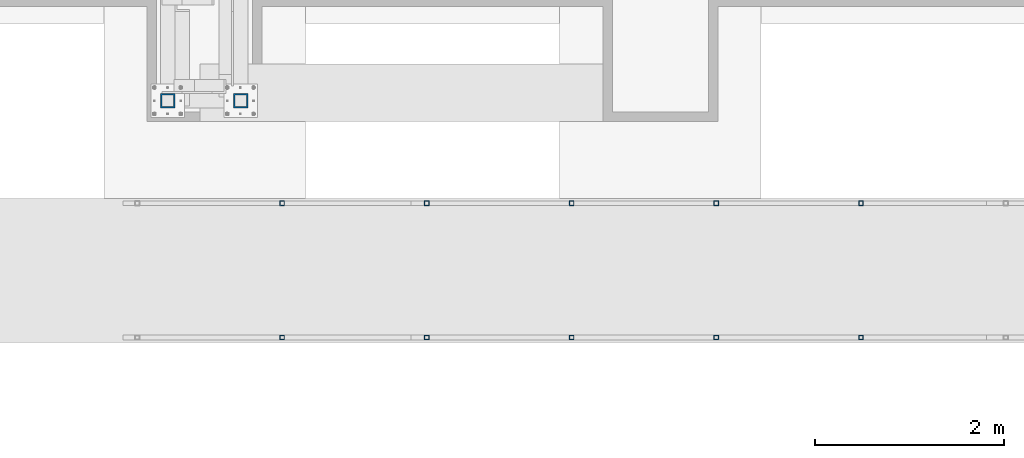
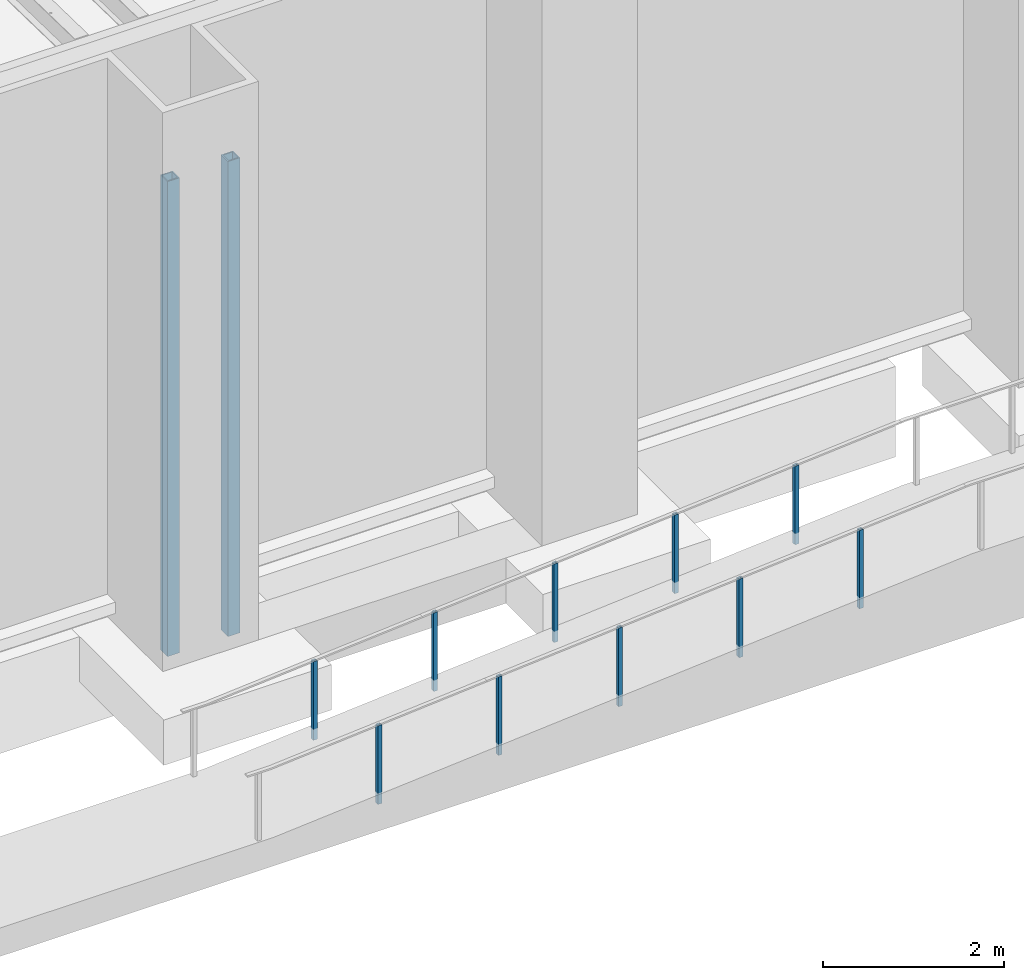
# One storey, part 876 of 1763: 12 columns, 5 elements without a shape of their own.
"""IFC2X3 building model written with IfcOpenShell, lengths in millimetres."""

from ifc_helpers import new_model, si_unit, frame, origin_with_axes, place, context, subcontext, project, spatial, faceted_brep, material, type_object, element, aggregate, save


model = new_model("IFC2X3")

# Units and contexts
model_context = context("Model", 3, precision=1e-05, world=origin_with_axes())
body_context = subcontext(model_context, "Body", "Model", "MODEL_VIEW")
ifc_project = project(units=[si_unit("LENGTHUNIT", "METRE", prefix="MILLI"), si_unit("AREAUNIT", "SQUARE_METRE"), si_unit("VOLUMEUNIT", "CUBIC_METRE"), si_unit("MASSUNIT", "GRAM", prefix="KILO"), si_unit("TIMEUNIT", "SECOND"), si_unit("PLANEANGLEUNIT", "RADIAN"), si_unit("SOLIDANGLEUNIT", "STERADIAN"), si_unit("THERMODYNAMICTEMPERATUREUNIT", "DEGREE_CELSIUS"), si_unit("LUMINOUSINTENSITYUNIT", "LUMEN")], contexts=[model_context])

# Site, building, storey
site_placement = place(None, origin_with_axes())
site = spatial("IfcSite", under=ifc_project, at=site_placement, CompositionType="ELEMENT")
building_placement = place(site_placement, origin_with_axes())
building = spatial("IfcBuilding", under=site, at=building_placement, Name="Undefined", CompositionType="ELEMENT")
storey_placement = place(building_placement, origin_with_axes())
storey = spatial("IfcBuildingStorey", under=building, at=storey_placement, Name="Undefined", CompositionType="ELEMENT", Elevation=0.0)

# Assembly, columns
assembly_1_placement = place(storey_placement, origin_with_axes())
assembly_1 = element("IfcElementAssembly", 1, at=assembly_1_placement, inside=storey, Name="FRAME", AssemblyPlace="NOTDEFINED", PredefinedType="RIGID_FRAME")
ifc_material = material()
column_type_1 = type_object("IfcColumnType", Name="HSS6X6X5/8", PredefinedType="NOTDEFINED")
column_1_placement = place(assembly_1_placement, frame((-80212.6370783858, -15452.7242675181, 5029.2), z_axis=(0.0, 1.0, 0.0), x_axis=(0.0, 0.0, 1.0)))
column_1 = element("IfcColumn", 2, at=column_1_placement, type_object=column_type_1, material=ifc_material, Name="COLUMN", ObjectType="HSS6X6X5/8", context=body_context, shape_type="Brep", body=[
    faceted_brep([(63.4999999999973, 60.3249999999971, -60.3250000000007), (63.4999999999973, -60.3249999999971, -60.3250000000007), (6457.95, -60.3249999999971, -60.3250000000007), (6457.95, 60.3249999999971, -60.3250000000007), (63.4999999999973, -60.3249999999971, 60.3250000000007), (6457.95, -60.3249999999971, 60.3250000000007), (63.4999999999973, 60.3249999999971, 60.3250000000007), (6457.95, 60.3249999999971, 60.3250000000007), (63.4999999999973, 76.1999999999971, -76.2000000000007), (63.4999999999973, 76.1999999999971, 76.2000000000007), (6457.95, 76.1999999999971, 76.2000000000007), (6457.95, 76.1999999999971, -76.2000000000007), (63.4999999999973, -76.1999999999971, 76.2000000000007), (6457.95, -76.1999999999971, 76.2000000000007), (63.4999999999973, -76.1999999999971, -76.2000000000007), (6457.95, -76.1999999999971, -76.2000000000007)], [[[0, 1, 2, 3]], [[1, 4, 5, 2]], [[4, 6, 7, 5]], [[6, 0, 3, 7]], [[8, 9, 10, 11]], [[9, 12, 13, 10]], [[12, 14, 15, 13]], [[14, 8, 11, 15]], [[13, 15, 11, 10], [5, 7, 3, 2]], [[14, 12, 9, 8], [6, 4, 1, 0]]]),
])
column_2_placement = place(assembly_1_placement, frame((-80984.1622736984, -15452.7242675181, 5029.2), z_axis=(0.0, 1.0, 0.0), x_axis=(0.0, 0.0, 1.0)))
column_2 = element("IfcColumn", 3, at=column_2_placement, type_object=column_type_1, material=ifc_material, Name="FRAME", ObjectType="HSS6X6X5/8", context=body_context, shape_type="Brep", body=[
    faceted_brep([(63.4999999999973, 60.3249999999971, -60.3250000000007), (63.4999999999973, -60.3249999999971, -60.3250000000007), (6457.95, -60.3249999999971, -60.3250000000007), (6457.95, 60.3249999999971, -60.3250000000007), (63.4999999999973, -60.3249999999971, 60.3250000000007), (6457.95, -60.3249999999971, 60.3250000000007), (63.4999999999973, 60.3249999999971, 60.3250000000007), (6457.95, 60.3249999999971, 60.3250000000007), (63.4999999999973, 76.1999999999971, -76.2000000000007), (63.4999999999973, 76.1999999999971, 76.2000000000007), (6457.95, 76.1999999999971, 76.2000000000007), (6457.95, 76.1999999999971, -76.2000000000007), (63.4999999999973, -76.1999999999971, 76.2000000000007), (6457.95, -76.1999999999971, 76.2000000000007), (63.4999999999973, -76.1999999999971, -76.2000000000007), (6457.95, -76.1999999999971, -76.2000000000007)], [[[0, 1, 2, 3]], [[1, 4, 5, 2]], [[4, 6, 7, 5]], [[6, 0, 3, 7]], [[8, 9, 10, 11]], [[9, 12, 13, 10]], [[12, 14, 15, 13]], [[14, 8, 11, 15]], [[13, 15, 11, 10], [5, 7, 3, 2]], [[14, 12, 9, 8], [6, 4, 1, 0]]]),
])
aggregate(assembly_1, [column_1, column_2])

assembly_2_placement = place(storey_placement, origin_with_axes())
assembly_2 = element("IfcElementAssembly", 4, at=assembly_2_placement, inside=storey, Name="HANDRAIL", AssemblyPlace="NOTDEFINED", PredefinedType="RIGID_FRAME")
column_type_2 = type_object("IfcColumnType", Name="2X2X3/16 SQUARE TUBE SS", PredefinedType="NOTDEFINED")
column_3_placement = place(assembly_2_placement, frame((-73642.7530471377, -16535.4002326199, 4635.59325414905), z_axis=(-0.999999999891248, 0.0, 1.47479999968709e-05), x_axis=(1.47479999970212e-05, 0.0, 0.999999999891248)))
column_3 = element("IfcColumn", 5, at=column_3_placement, type_object=column_type_2, material=ifc_material, Name="POST TUBE", ObjectType="2X2X3/16 SQUARE TUBE SS", context=body_context, shape_type="Brep", body=[
    faceted_brep([(0.0, 20.6375000000007, -20.6374999999971), (0.0, -20.6375000000007, -20.6374999999971), (1058.85892867167, -20.6375000000007, -20.6375000025291), (1058.85892867167, 20.6375000000007, -20.6375000025291), (0.0, -20.6375000000007, 20.6374999999971), (1055.5862839151, -20.6375000000007, 20.6374999977415), (0.0, 20.6375000000007, 20.6374999999971), (1055.5862839151, 20.6375000000007, 20.6374999977415), (-1.45519152283669e-11, 25.4000000000015, -25.3999999999869), (1.45519152283669e-11, 25.4000000000015, 25.3999999999796), (1055.20867105857, 25.4000000000015, 25.3999999977968), (1059.2365415282, 25.4000000000015, -25.4000000025844), (0.0, -25.4000000000015, 25.3999999999942), (1055.20867105857, -25.4000000000015, 25.3999999977968), (-1.45519152283669e-11, -25.4000000000015, -25.3999999999869), (1059.2365415282, -25.4000000000015, -25.4000000025844)], [[[0, 1, 2, 3]], [[1, 4, 5, 2]], [[4, 6, 7, 5]], [[6, 0, 3, 7]], [[8, 9, 10, 11]], [[9, 12, 13, 10]], [[12, 14, 15, 13]], [[14, 8, 11, 15]], [[13, 15, 11, 10], [5, 7, 3, 2]], [[14, 12, 9, 8], [6, 4, 1, 0]]]),
])
column_4_placement = place(assembly_2_placement, frame((-75175.4841177522, -16535.4002326199, 4514.08826844872), z_axis=(-0.999999999891248, 0.0, 1.47479999968709e-05), x_axis=(1.47479999970212e-05, 0.0, 0.999999999891248)))
column_4 = element("IfcColumn", 6, at=column_4_placement, type_object=column_type_2, material=ifc_material, Name="POST TUBE", ObjectType="2X2X3/16 SQUARE TUBE SS", context=body_context, shape_type="Brep", body=[
    faceted_brep([(0.0, 20.6375000000007, -20.6374999999971), (0.0, -20.6375000000007, -20.6374999999971), (1058.85827107218, -20.6375000000007, -20.6375000025582), (1058.85827107218, 20.6375000000007, -20.6375000025582), (0.0, -20.6375000000007, 20.6374999999971), (1055.58562631561, -20.6375000000007, 20.6374999977415), (0.0, 20.6375000000007, 20.6374999999971), (1055.58562631561, 20.6375000000007, 20.6374999977415), (-1.45519152283669e-11, 25.4000000000015, -25.3999999999869), (1.45519152283669e-11, 25.4000000000015, 25.3999999999796), (1055.20801345908, 25.4000000000015, 25.3999999977677), (1059.23588392871, 25.4000000000015, -25.4000000025844), (0.0, -25.4000000000015, 25.3999999999942), (1055.20801345908, -25.4000000000015, 25.3999999977677), (-1.45519152283669e-11, -25.4000000000015, -25.3999999999869), (1059.23588392871, -25.4000000000015, -25.4000000025844)], [[[0, 1, 2, 3]], [[1, 4, 5, 2]], [[4, 6, 7, 5]], [[6, 0, 3, 7]], [[8, 9, 10, 11]], [[9, 12, 13, 10]], [[12, 14, 15, 13]], [[14, 8, 11, 15]], [[13, 15, 11, 10], [5, 7, 3, 2]], [[14, 12, 9, 8], [6, 4, 1, 0]]]),
])
column_5_placement = place(assembly_2_placement, frame((-76708.2153367928, -16535.4002326199, 4392.58327098213), z_axis=(-0.999999999891248, 0.0, 1.47479999968709e-05), x_axis=(1.47479999970212e-05, 0.0, 0.999999999891248)))
column_5 = element("IfcColumn", 7, at=column_5_placement, type_object=column_type_2, material=ifc_material, Name="POST TUBE", ObjectType="2X2X3/16 SQUARE TUBE SS", context=body_context, shape_type="Brep", body=[
    faceted_brep([(0.0, 20.6375000000007, -20.6374999999971), (0.0, -20.6375000000007, -20.6374999999971), (1058.85761347263, -20.6375000000007, -20.6375000025582), (1058.85761347263, 20.6375000000007, -20.6375000025582), (0.0, -20.6375000000007, 20.6374999999971), (1055.58496871605, -20.6375000000007, 20.6374999977561), (0.0, 20.6375000000007, 20.6374999999971), (1055.58496871605, 20.6375000000007, 20.6374999977561), (-1.45519152283669e-11, 25.4000000000015, -25.3999999999869), (1.45519152283669e-11, 25.4000000000015, 25.3999999999796), (1055.20735585953, 25.4000000000015, 25.3999999977823), (1059.23522632916, 25.4000000000015, -25.4000000025844), (0.0, -25.4000000000015, 25.3999999999942), (1055.20735585953, -25.4000000000015, 25.3999999977823), (-1.45519152283669e-11, -25.4000000000015, -25.3999999999869), (1059.23522632916, -25.4000000000015, -25.4000000025844)], [[[0, 1, 2, 3]], [[1, 4, 5, 2]], [[4, 6, 7, 5]], [[6, 0, 3, 7]], [[8, 9, 10, 11]], [[9, 12, 13, 10]], [[12, 14, 15, 13]], [[14, 8, 11, 15]], [[13, 15, 11, 10], [5, 7, 3, 2]], [[14, 12, 9, 8], [6, 4, 1, 0]]]),
])
column_6_placement = place(assembly_2_placement, frame((-78240.9462589812, -16535.4002326199, 4271.07829704804), z_axis=(-0.999999999891248, 0.0, 1.47479999968709e-05), x_axis=(1.47479999970212e-05, 0.0, 0.999999999891248)))
column_6 = element("IfcColumn", 8, at=column_6_placement, type_object=column_type_2, material=ifc_material, Name="POST TUBE", ObjectType="2X2X3/16 SQUARE TUBE SS", context=body_context, shape_type="Brep", body=[
    faceted_brep([(0.0, 20.6375000000007, -20.6374999999971), (0.0, -20.6375000000007, -20.6374999999971), (1058.8569558732, -20.6375000000007, -20.6375000025582), (1058.8569558732, 20.6375000000007, -20.6375000025582), (0.0, -20.6375000000007, 20.6374999999971), (1055.58431111663, -20.6375000000007, 20.637499997727), (0.0, 20.6375000000007, 20.6374999999971), (1055.58431111663, 20.6375000000007, 20.637499997727), (-1.45519152283669e-11, 25.4000000000015, -25.3999999999869), (1.45519152283669e-11, 25.4000000000015, 25.3999999999796), (1055.2066982601, 25.4000000000015, 25.3999999977677), (1059.23456872973, 25.4000000000015, -25.400000002599), (0.0, -25.4000000000015, 25.3999999999942), (1055.2066982601, -25.4000000000015, 25.3999999977677), (-1.45519152283669e-11, -25.4000000000015, -25.3999999999869), (1059.23456872973, -25.4000000000015, -25.400000002599)], [[[0, 1, 2, 3]], [[1, 4, 5, 2]], [[4, 6, 7, 5]], [[6, 0, 3, 7]], [[8, 9, 10, 11]], [[9, 12, 13, 10]], [[12, 14, 15, 13]], [[14, 8, 11, 15]], [[13, 15, 11, 10], [5, 7, 3, 2]], [[14, 12, 9, 8], [6, 4, 1, 0]]]),
])
aggregate(assembly_2, [column_3, column_4, column_5, column_6])

# Assembly, column
assembly_3_placement = place(storey_placement, origin_with_axes())
assembly_3 = element("IfcElementAssembly", 9, at=assembly_3_placement, inside=storey, Name="HANDRAIL", AssemblyPlace="NOTDEFINED", PredefinedType="RIGID_FRAME")
column_7_placement = place(assembly_3_placement, frame((-79773.6773295958, -16535.4002326199, 4149.57331134771), z_axis=(-0.999999999891248, 0.0, 1.47479999968709e-05), x_axis=(1.47479999970212e-05, 0.0, 0.999999999891248)))
column_7 = element("IfcColumn", 10, at=column_7_placement, type_object=column_type_2, material=ifc_material, Name="POST TUBE", ObjectType="2X2X3/16 SQUARE TUBE SS", context=body_context, shape_type="Brep", body=[
    faceted_brep([(0.0, 20.6375000000007, -20.6374999999971), (0.0, -20.6375000000007, -20.6374999999971), (1058.85630556204, -20.6375000000007, -20.6375000025582), (1058.85630556204, 20.6375000000007, -20.6375000025582), (0.0, -20.6375000000007, 20.6374999999971), (1055.58366059844, -20.6375000000007, 20.6374999977415), (0.0, 20.6375000000007, 20.6374999999971), (1055.58366059844, 20.6375000000007, 20.6374999977415), (-1.45519152283669e-11, 25.4000000000015, -25.3999999999869), (1.45519152283669e-11, 25.4000000000015, 25.3999999999796), (1055.20604771802, 25.4000000000015, 25.3999999977677), (1059.23391844245, 25.4000000000015, -25.4000000025844), (0.0, -25.4000000000015, 25.3999999999942), (1055.20604771802, -25.4000000000015, 25.3999999977677), (-1.45519152283669e-11, -25.4000000000015, -25.3999999999869), (1059.23391844245, -25.4000000000015, -25.4000000025844)], [[[0, 1, 2, 3]], [[1, 4, 5, 2]], [[4, 6, 7, 5]], [[6, 0, 3, 7]], [[8, 9, 10, 11]], [[9, 12, 13, 10]], [[12, 14, 15, 13]], [[14, 8, 11, 15]], [[13, 15, 11, 10], [5, 7, 3, 2]], [[14, 12, 9, 8], [6, 4, 1, 0]]]),
])
aggregate(assembly_3, [column_7])

# Assembly, columns
assembly_4_placement = place(storey_placement, origin_with_axes())
assembly_4 = element("IfcElementAssembly", 11, at=assembly_4_placement, inside=storey, Name="HANDRAIL", AssemblyPlace="NOTDEFINED", PredefinedType="RIGID_FRAME")
column_8_placement = place(assembly_4_placement, frame((-73642.7530471377, -17957.80011631, 4635.59325414905), z_axis=(-0.999999999891248, 0.0, 1.47479999968709e-05), x_axis=(1.47479999970212e-05, 0.0, 0.999999999891248)))
column_8 = element("IfcColumn", 12, at=column_8_placement, type_object=column_type_2, material=ifc_material, Name="POST TUBE", ObjectType="2X2X3/16 SQUARE TUBE SS", context=body_context, shape_type="Brep", body=[
    faceted_brep([(0.0, 20.6375000000007, -20.6374999999971), (0.0, -20.6375000000007, -20.6374999999971), (1058.85892867167, -20.6375000000007, -20.6375000025291), (1058.85892867167, 20.6375000000007, -20.6375000025291), (0.0, -20.6375000000007, 20.6374999999971), (1055.5862839151, -20.6375000000007, 20.6374999977415), (0.0, 20.6375000000007, 20.6374999999971), (1055.5862839151, 20.6375000000007, 20.6374999977415), (-1.45519152283669e-11, 25.4000000000015, -25.3999999999869), (1.45519152283669e-11, 25.4000000000015, 25.3999999999796), (1055.20867105857, 25.4000000000015, 25.3999999977968), (1059.2365415282, 25.4000000000015, -25.4000000025844), (0.0, -25.4000000000015, 25.3999999999942), (1055.20867105857, -25.4000000000015, 25.3999999977968), (-1.45519152283669e-11, -25.4000000000015, -25.3999999999869), (1059.2365415282, -25.4000000000015, -25.4000000025844)], [[[0, 1, 2, 3]], [[1, 4, 5, 2]], [[4, 6, 7, 5]], [[6, 0, 3, 7]], [[8, 9, 10, 11]], [[9, 12, 13, 10]], [[12, 14, 15, 13]], [[14, 8, 11, 15]], [[13, 15, 11, 10], [5, 7, 3, 2]], [[14, 12, 9, 8], [6, 4, 1, 0]]]),
])
column_9_placement = place(assembly_4_placement, frame((-75175.4841177522, -17957.80011631, 4514.08826844872), z_axis=(-0.999999999891248, 0.0, 1.47479999968709e-05), x_axis=(1.47479999970212e-05, 0.0, 0.999999999891248)))
column_9 = element("IfcColumn", 13, at=column_9_placement, type_object=column_type_2, material=ifc_material, Name="POST TUBE", ObjectType="2X2X3/16 SQUARE TUBE SS", context=body_context, shape_type="Brep", body=[
    faceted_brep([(0.0, 20.6375000000007, -20.6374999999971), (0.0, -20.6375000000007, -20.6374999999971), (1058.85827107218, -20.6375000000007, -20.6375000025582), (1058.85827107218, 20.6375000000007, -20.6375000025582), (0.0, -20.6375000000007, 20.6374999999971), (1055.58562631561, -20.6375000000007, 20.6374999977415), (0.0, 20.6375000000007, 20.6374999999971), (1055.58562631561, 20.6375000000007, 20.6374999977415), (-1.45519152283669e-11, 25.4000000000015, -25.3999999999869), (1.45519152283669e-11, 25.4000000000015, 25.3999999999796), (1055.20801345908, 25.4000000000015, 25.3999999977677), (1059.23588392871, 25.4000000000015, -25.4000000025844), (0.0, -25.4000000000015, 25.3999999999942), (1055.20801345908, -25.4000000000015, 25.3999999977677), (-1.45519152283669e-11, -25.4000000000015, -25.3999999999869), (1059.23588392871, -25.4000000000015, -25.4000000025844)], [[[0, 1, 2, 3]], [[1, 4, 5, 2]], [[4, 6, 7, 5]], [[6, 0, 3, 7]], [[8, 9, 10, 11]], [[9, 12, 13, 10]], [[12, 14, 15, 13]], [[14, 8, 11, 15]], [[13, 15, 11, 10], [5, 7, 3, 2]], [[14, 12, 9, 8], [6, 4, 1, 0]]]),
])
column_10_placement = place(assembly_4_placement, frame((-76708.2153367928, -17957.80011631, 4392.58327098213), z_axis=(-0.999999999891248, 0.0, 1.47479999968709e-05), x_axis=(1.47479999970212e-05, 0.0, 0.999999999891248)))
column_10 = element("IfcColumn", 14, at=column_10_placement, type_object=column_type_2, material=ifc_material, Name="POST TUBE", ObjectType="2X2X3/16 SQUARE TUBE SS", context=body_context, shape_type="Brep", body=[
    faceted_brep([(0.0, 20.6375000000007, -20.6374999999971), (0.0, -20.6375000000007, -20.6374999999971), (1058.85761347263, -20.6375000000007, -20.6375000025582), (1058.85761347263, 20.6375000000007, -20.6375000025582), (0.0, -20.6375000000007, 20.6374999999971), (1055.58496871605, -20.6375000000007, 20.6374999977561), (0.0, 20.6375000000007, 20.6374999999971), (1055.58496871605, 20.6375000000007, 20.6374999977561), (-1.45519152283669e-11, 25.4000000000015, -25.3999999999869), (1.45519152283669e-11, 25.4000000000015, 25.3999999999796), (1055.20735585953, 25.4000000000015, 25.3999999977823), (1059.23522632916, 25.4000000000015, -25.4000000025844), (0.0, -25.4000000000015, 25.3999999999942), (1055.20735585953, -25.4000000000015, 25.3999999977823), (-1.45519152283669e-11, -25.4000000000015, -25.3999999999869), (1059.23522632916, -25.4000000000015, -25.4000000025844)], [[[0, 1, 2, 3]], [[1, 4, 5, 2]], [[4, 6, 7, 5]], [[6, 0, 3, 7]], [[8, 9, 10, 11]], [[9, 12, 13, 10]], [[12, 14, 15, 13]], [[14, 8, 11, 15]], [[13, 15, 11, 10], [5, 7, 3, 2]], [[14, 12, 9, 8], [6, 4, 1, 0]]]),
])
column_11_placement = place(assembly_4_placement, frame((-78240.9462589812, -17957.80011631, 4271.07829704804), z_axis=(-0.999999999891248, 0.0, 1.47479999968709e-05), x_axis=(1.47479999970212e-05, 0.0, 0.999999999891248)))
column_11 = element("IfcColumn", 15, at=column_11_placement, type_object=column_type_2, material=ifc_material, Name="POST TUBE", ObjectType="2X2X3/16 SQUARE TUBE SS", context=body_context, shape_type="Brep", body=[
    faceted_brep([(0.0, 20.6375000000007, -20.6374999999971), (0.0, -20.6375000000007, -20.6374999999971), (1058.8569558732, -20.6375000000007, -20.6375000025582), (1058.8569558732, 20.6375000000007, -20.6375000025582), (0.0, -20.6375000000007, 20.6374999999971), (1055.58431111663, -20.6375000000007, 20.637499997727), (0.0, 20.6375000000007, 20.6374999999971), (1055.58431111663, 20.6375000000007, 20.637499997727), (-1.45519152283669e-11, 25.4000000000015, -25.3999999999869), (1.45519152283669e-11, 25.4000000000015, 25.3999999999796), (1055.2066982601, 25.4000000000015, 25.3999999977677), (1059.23456872973, 25.4000000000015, -25.400000002599), (0.0, -25.4000000000015, 25.3999999999942), (1055.2066982601, -25.4000000000015, 25.3999999977677), (-1.45519152283669e-11, -25.4000000000015, -25.3999999999869), (1059.23456872973, -25.4000000000015, -25.400000002599)], [[[0, 1, 2, 3]], [[1, 4, 5, 2]], [[4, 6, 7, 5]], [[6, 0, 3, 7]], [[8, 9, 10, 11]], [[9, 12, 13, 10]], [[12, 14, 15, 13]], [[14, 8, 11, 15]], [[13, 15, 11, 10], [5, 7, 3, 2]], [[14, 12, 9, 8], [6, 4, 1, 0]]]),
])
aggregate(assembly_4, [column_8, column_9, column_10, column_11])

# Assembly, column
assembly_5_placement = place(storey_placement, origin_with_axes())
assembly_5 = element("IfcElementAssembly", 16, at=assembly_5_placement, inside=storey, Name="HANDRAIL", AssemblyPlace="NOTDEFINED", PredefinedType="RIGID_FRAME")
column_12_placement = place(assembly_5_placement, frame((-79773.6773295958, -17957.80011631, 4149.57331134771), z_axis=(-0.999999999891248, 0.0, 1.47479999968709e-05), x_axis=(1.47479999970212e-05, 0.0, 0.999999999891248)))
column_12 = element("IfcColumn", 17, at=column_12_placement, type_object=column_type_2, material=ifc_material, Name="POST TUBE", ObjectType="2X2X3/16 SQUARE TUBE SS", context=body_context, shape_type="Brep", body=[
    faceted_brep([(0.0, 20.6375000000007, -20.6374999999971), (0.0, -20.6375000000007, -20.6374999999971), (1058.85630556204, -20.6375000000007, -20.6375000025582), (1058.85630556204, 20.6375000000007, -20.6375000025582), (0.0, -20.6375000000007, 20.6374999999971), (1055.58366059844, -20.6375000000007, 20.6374999977415), (0.0, 20.6375000000007, 20.6374999999971), (1055.58366059844, 20.6375000000007, 20.6374999977415), (-1.45519152283669e-11, 25.4000000000015, -25.3999999999869), (1.45519152283669e-11, 25.4000000000015, 25.3999999999796), (1055.20604771802, 25.4000000000015, 25.3999999977677), (1059.23391844245, 25.4000000000015, -25.4000000025844), (0.0, -25.4000000000015, 25.3999999999942), (1055.20604771802, -25.4000000000015, 25.3999999977677), (-1.45519152283669e-11, -25.4000000000015, -25.3999999999869), (1059.23391844245, -25.4000000000015, -25.4000000025844)], [[[0, 1, 2, 3]], [[1, 4, 5, 2]], [[4, 6, 7, 5]], [[6, 0, 3, 7]], [[8, 9, 10, 11]], [[9, 12, 13, 10]], [[12, 14, 15, 13]], [[14, 8, 11, 15]], [[13, 15, 11, 10], [5, 7, 3, 2]], [[14, 12, 9, 8], [6, 4, 1, 0]]]),
])
aggregate(assembly_5, [column_12])

save(model, "model.ifc")
